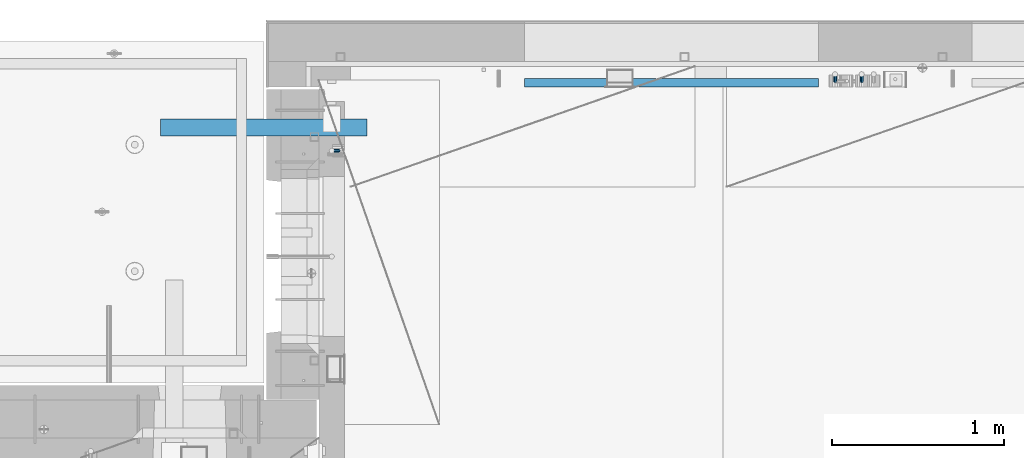
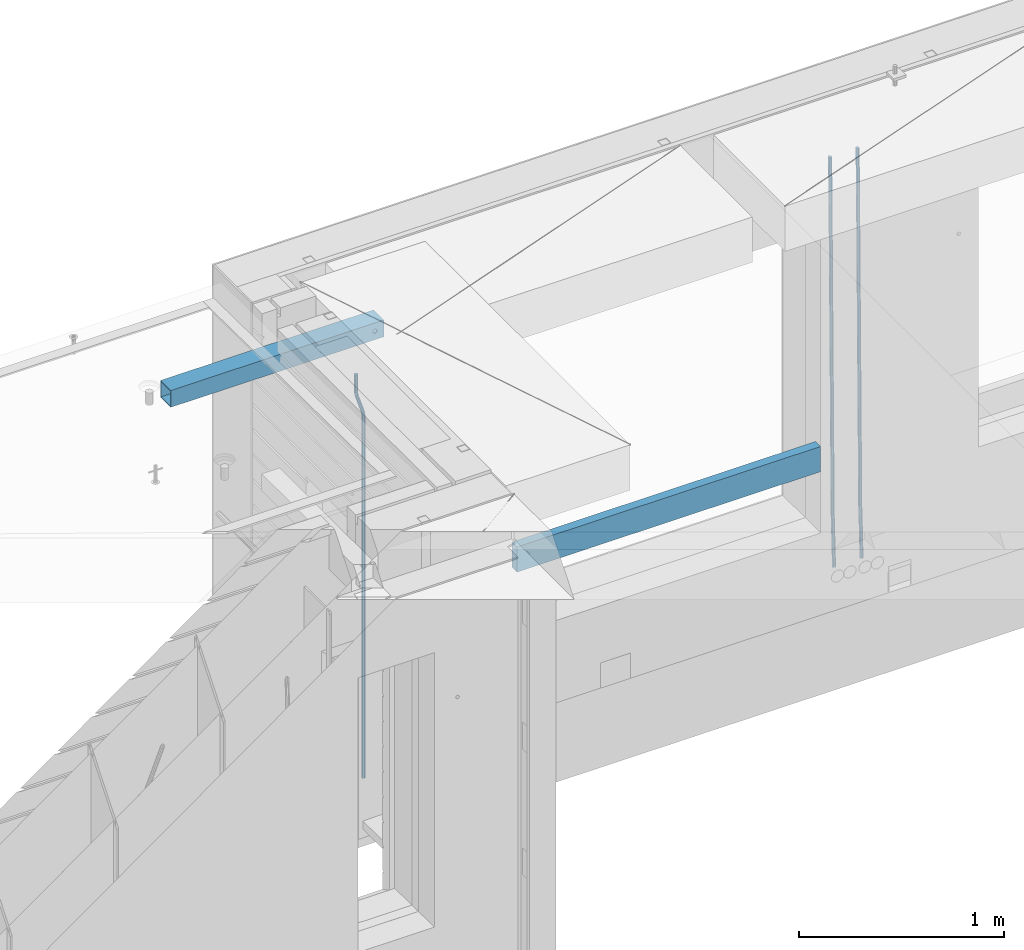
# One storey, part 117 of 350: 5 beams, 4 elements without a shape of their own.
"""IFC2X3 building model written with IfcOpenShell, lengths in millimetres."""

from ifc_helpers import new_model, si_unit, frame, origin_with_axes, place, context, subcontext, project, spatial, faceted_brep, material, type_object, element, aggregate, save


model = new_model("IFC2X3")

# Units and contexts
model_context = context("Model", 3, precision=1e-05, world=origin_with_axes())
body_context = subcontext(model_context, "Body", "Model", "MODEL_VIEW")
ifc_project = project(units=[si_unit("LENGTHUNIT", "METRE", prefix="MILLI"), si_unit("AREAUNIT", "SQUARE_METRE"), si_unit("VOLUMEUNIT", "CUBIC_METRE"), si_unit("MASSUNIT", "GRAM", prefix="KILO"), si_unit("TIMEUNIT", "SECOND"), si_unit("PLANEANGLEUNIT", "RADIAN"), si_unit("SOLIDANGLEUNIT", "STERADIAN"), si_unit("THERMODYNAMICTEMPERATUREUNIT", "DEGREE_CELSIUS"), si_unit("LUMINOUSINTENSITYUNIT", "LUMEN")], contexts=[model_context])

# Site, building, storey
site_placement = place(None, origin_with_axes())
site = spatial("IfcSite", under=ifc_project, at=site_placement, CompositionType="ELEMENT")
building_placement = place(site_placement, origin_with_axes())
building = spatial("IfcBuilding", under=site, at=building_placement, CompositionType="ELEMENT")
storey_placement = place(building_placement, origin_with_axes())
storey = spatial("IfcBuildingStorey", under=building, at=storey_placement, Name="2", CompositionType="ELEMENT", Elevation=0.0)

# Assembly, beams
assembly_1_placement = place(storey_placement, origin_with_axes())
assembly_1 = element("IfcElementAssembly", 1, at=assembly_1_placement, inside=storey, AssemblyPlace="NOTDEFINED", PredefinedType="REINFORCEMENT_UNIT")
ifc_material_1 = material()
beam_type_1 = type_object("IfcBeamType", Name="D20", PredefinedType="NOTDEFINED")
beam_1_placement = place(assembly_1_placement, frame((13990.0000000039, 22654.9999977209, 84990.0), z_axis=(-0.000205762999925498, 0.999642804629538, -0.0267249099901004), x_axis=(4.30000201928125e-08, 0.0267249099948059, 0.999642825806181)))
beam_1 = element("IfcBeam", 2, at=beam_1_placement, type_object=beam_type_1, material=ifc_material_1, Name="JM20", ObjectType="D20", context=body_context, shape_type="Brep", body=[
    faceted_brep([(0.0, -10.0, 0.0), (-4.19531716033816e-08, -7.07106781186667, -7.07106781187031), (60.4266690400545, -7.0710677960451, -7.07106780570757), (60.4266690441291, -9.99999998418934, 6.15546014159918e-09), (0.0, 0.0, -10.0), (60.426669036824, 1.58106558956206e-08, -9.99999999384454), (4.196772351861e-08, 7.07106781186303, -7.07106781186667), (60.4266690363438, 7.07106782768096, -7.07106780570757), (0.0, 10.0, 0.0), (60.4266690388904, 10.0000000158179, 6.15182216279209e-09), (4.196772351861e-08, 7.07106781185939, 7.07106781185939), (60.4266690429649, 7.07106782768096, 7.07106781802577), (0.0, 0.0, 10.0), (60.4266690461809, 1.58179318532348e-08, 10.0000000061555), (-4.19531716033816e-08, -7.07106781187031, 7.07106781185939), (60.4266690466611, -7.07106779605238, 7.07106781802213), (61.0378400410118, -7.07106779588503, -7.07106780564936), (60.991799419251, -9.99999998403655, 6.21366780251265e-09), (61.0569027789461, 1.5985278878361e-08, -9.99999999378269), (61.0378209396877, 7.07106782784831, -7.07106780564936), (60.9917724058905, 10.0000000159635, 6.21366780251265e-09), (60.9457317841297, 7.07106782781193, 7.0710678180767), (60.9266690461809, 1.59488990902901e-08, 10.0000000062028), (60.9457508854539, -7.07106779591413, 7.0710678180767), (61.6489592143771, -7.07106614513759, -7.06310863441468), (61.5568818710308, -9.9999984576425, 0.00735959856683621), (61.6870830769039, 1.71821739058942e-06, -9.99179257185824), (61.6489210170112, 7.07106947854481, -7.06310888312146), (61.556827851804, 10.0000015422847, 0.00735924683976918), (61.4647505084577, 7.07106922979438, 7.07782747982128), (61.4266266459163, 1.36643211590126e-06, 10.0065114172685), (61.464788705809, -7.07106639389531, 7.07782772852806), (176.543135720174, -7.07075579406956, -5.56673531796696), (176.451058376813, -9.99968810657447, 1.50373291501455), (176.581259582701, 0.000312069292704109, -8.49541925541052), (176.543097522794, 7.07137982961285, -5.56673556667374), (176.451004357587, 10.00031189336, 1.50373256329476), (176.35892701424, 7.07137958085514, 8.57420079627263), (176.320803151699, 0.000311717507429421, 11.5028847337162), (176.358965211621, -7.07075604281999, 8.57420104497578), (177.098753836006, -7.07075429323595, -5.55949898843028), (176.98362511232, -9.99968666800123, 1.510669025065), (177.146421932586, 0.000313595905026887, -8.48805862247536), (177.098706077581, 7.07138133041735, -5.55949936166144), (176.983557571715, 10.0003133318824, 1.51066849724157), (176.868428848029, 7.07138095712435, 8.58083651073321), (176.820760751449, 0.000313067976094317, 11.5093961447819), (176.868476606425, -7.07075466652896, 8.58083688396073), (177.654312950661, -7.07075204110879, -5.54863964998367), (177.516135294456, -9.99968450931192, 1.52107783331303), (177.711524267797, 0.000315886711177882, -8.47701274570863), (177.654255632195, 7.07138358250813, -5.54864021007961), (177.516054233929, 10.0003154905207, 1.5210770412159), (177.377876577739, 7.0713830223176, 8.59079452451624), (177.320665260588, 0.000315094497636892, 11.5191676202448), (177.377933896176, -7.07075260129932, 8.59079508461218), (299.436796249574, -7.07025836271714, -3.1681962331204), (299.298618593355, -9.99919083092027, 3.90152125031091), (299.494007566798, 0.000809565110102994, -6.09656932889993), (299.436738931283, 7.07187726089978, -3.16819679320906), (299.298537533061, 10.0008091689197, 3.90152045822106), (299.160359876842, 7.07187670072017, 10.9712379416487), (299.103148559603, 0.000808772889286047, 13.8996110374392), (299.160417195119, -7.07025892290039, 10.9712385017483), (299.98743051647, -7.07025613056248, -3.15743315966392), (299.971788958996, -9.99918809853989, 3.91467979818117), (299.993912075952, 0.000811591617093654, -6.08679785393178), (299.987423933868, 7.07187949325817, -3.1574327280432), (299.971753863239, 10.0008119014747, 3.91467990454839), (299.95611230444, 7.07187992653053, 10.9867922621015), (299.949630744944, 0.000812204350950196, 13.9161569563694), (299.956118887014, -7.07025569729012, 10.9867918304735), (300.538107039494, -7.07025785017686, -3.16575821840888), (300.644985195438, -9.99919020432935, 3.90450175465594), (300.493854948218, 0.000810030429420294, -6.09435592770024), (300.538151196495, 7.071877773491, -3.16575855385963), (300.645047642858, 10.0008097955724, 3.90450128024895), (300.751925798773, 7.07187744142357, 10.9747612533101), (300.796177890064, 0.000809560813650023, 13.9033589625978), (300.751881641787, -7.07025818224065, 10.9747615887682), (2293.36490490142, -7.07648090940347, -33.2930642912361), (2293.47178305736, -10.0054132635523, -26.2228043181785), (2293.32065281013, -0.00541302880083094, -36.2216620005347), (2293.36494905842, 7.06565471425711, -33.2930646266868), (2293.47184550477, 9.99458673634581, -26.2228047925819), (2293.57872366071, 7.06565438219332, -19.1525448195243), (2293.62297575199, -0.00541349841296324, -16.2239471102366), (2293.57867950371, -7.0764812414709, -19.1525444840736), (2294.0658245362, -7.07648309818615, -33.3036607065333), (2294.05312277409, -10.0054150789219, -26.2315929392535), (2294.10928714235, -0.00541549149056664, -36.2335844756526), (2294.15805078732, 7.06565223761572, -33.3050546393533), (2294.18355038921, 9.99458451388637, -26.2335642579346), (2294.17084862708, 7.06565253314329, -19.1614964906439), (2294.12738602093, -0.00541507354500936, -16.2315727215355), (2294.07862237596, -7.07648280265857, -19.1601025578348), (2294.76670261032, -7.08562269121467, -33.294332712383), (2294.63442802057, -10.0129954178956, -26.2238563411993), (2294.89787471293, -0.0156988342423574, -36.2230891548279), (2294.95110548967, 7.05531064255774, -33.2944998654275), (2294.89521307347, 9.98530428734011, -26.2240927312887), (2294.76293848372, 7.0579315606592, -19.1536163601049), (2294.63176638114, -0.0119922963167483, -16.2248599176673), (2294.57853560438, -7.08300177311321, -19.1534492070678), (2316.52657204497, -7.36937582653991, -33.0047303660212), (2316.39429745522, -10.2967485532172, -25.9342539948302), (2316.65774414754, -0.299451969567599, -35.9334868084661), (2316.7109749243, 6.7715575072325, -33.0048975190657), (2316.65508250811, 9.70155115201487, -25.9344903849269), (2316.52280791836, 6.7741784253376, -18.8640140137468), (2316.39163581574, -0.295745431634714, -15.9352575713092), (2316.33840503903, -7.36675490843481, -18.863846860706), (2317.16202064224, -7.37766220584308, -32.9962731735213), (2317.05438744847, -10.3053562613532, -25.9254688497131), (2317.23607125619, -0.306993473008333, -35.925789846493), (2317.23316144495, 6.76474808850253, -32.9979477328052), (2317.15499573652, 9.6950321815566, -25.9278370341635), (2317.04736254275, 6.7673381260538, -18.8570327103698), (2316.97331192881, -0.303330606784584, -15.9275160373909), (2316.97622174003, -7.37507216829545, -18.8553581510787), (2317.79752306276, -7.37578610372293, -32.9880110666527), (2317.71453320107, -10.3033876998124, -25.9168792378296), (2317.81444760226, -0.305295583297266, -35.918287695793), (2317.75539265381, 6.76628640723357, -32.9911928173897), (2317.65495180529, 9.69652304524061, -25.9213789128698), (2317.5719619436, 6.76892144914746, -18.8502470840467), (2317.55503740412, -0.301569071270933, -15.9199704549137), (2317.61409235255, -7.3731510618054, -18.847065333317), (2417.8183084176, -7.07752398473531, -31.6906369377139), (2417.73531855589, -10.0051255808248, -24.6195051088798), (2417.83523295709, -0.007033464313281, -34.6209135668432), (2417.77617800863, 7.06454852621755, -31.6938186884508), (2417.67573716014, 9.99478516423187, -24.6240047839383), (2417.59274729842, 7.06718356813872, -17.5528729551006), (2417.57582275895, -0.00330695228694822, -14.6225963259749), (2417.6348777074, -7.07488894281778, -17.5496912043673)], [[[0, 1, 2, 3]], [[1, 4, 5, 2]], [[4, 6, 7, 5]], [[6, 8, 9, 7]], [[8, 10, 11, 9]], [[10, 12, 13, 11]], [[12, 14, 15, 13]], [[14, 0, 3, 15]], [[14, 12, 10, 8, 6, 4, 1, 0]], [[3, 2, 16, 17]], [[2, 5, 18, 16]], [[5, 7, 19, 18]], [[7, 9, 20, 19]], [[9, 11, 21, 20]], [[11, 13, 22, 21]], [[13, 15, 23, 22]], [[15, 3, 17, 23]], [[17, 16, 24, 25]], [[16, 18, 26, 24]], [[18, 19, 27, 26]], [[19, 20, 28, 27]], [[20, 21, 29, 28]], [[21, 22, 30, 29]], [[22, 23, 31, 30]], [[23, 17, 25, 31]], [[25, 24, 32, 33]], [[24, 26, 34, 32]], [[26, 27, 35, 34]], [[27, 28, 36, 35]], [[28, 29, 37, 36]], [[29, 30, 38, 37]], [[30, 31, 39, 38]], [[31, 25, 33, 39]], [[33, 32, 40, 41]], [[32, 34, 42, 40]], [[34, 35, 43, 42]], [[35, 36, 44, 43]], [[36, 37, 45, 44]], [[37, 38, 46, 45]], [[38, 39, 47, 46]], [[39, 33, 41, 47]], [[41, 40, 48, 49]], [[40, 42, 50, 48]], [[42, 43, 51, 50]], [[43, 44, 52, 51]], [[44, 45, 53, 52]], [[45, 46, 54, 53]], [[46, 47, 55, 54]], [[47, 41, 49, 55]], [[49, 48, 56, 57]], [[48, 50, 58, 56]], [[50, 51, 59, 58]], [[51, 52, 60, 59]], [[52, 53, 61, 60]], [[53, 54, 62, 61]], [[54, 55, 63, 62]], [[55, 49, 57, 63]], [[57, 56, 64, 65]], [[56, 58, 66, 64]], [[58, 59, 67, 66]], [[59, 60, 68, 67]], [[60, 61, 69, 68]], [[61, 62, 70, 69]], [[62, 63, 71, 70]], [[63, 57, 65, 71]], [[65, 64, 72, 73]], [[64, 66, 74, 72]], [[66, 67, 75, 74]], [[67, 68, 76, 75]], [[68, 69, 77, 76]], [[69, 70, 78, 77]], [[70, 71, 79, 78]], [[71, 65, 73, 79]], [[73, 72, 80, 81]], [[72, 74, 82, 80]], [[74, 75, 83, 82]], [[75, 76, 84, 83]], [[76, 77, 85, 84]], [[77, 78, 86, 85]], [[78, 79, 87, 86]], [[79, 73, 81, 87]], [[81, 80, 88, 89]], [[80, 82, 90, 88]], [[82, 83, 91, 90]], [[83, 84, 92, 91]], [[84, 85, 93, 92]], [[85, 86, 94, 93]], [[86, 87, 95, 94]], [[87, 81, 89, 95]], [[89, 88, 96, 97]], [[88, 90, 98, 96]], [[90, 91, 99, 98]], [[91, 92, 100, 99]], [[92, 93, 101, 100]], [[93, 94, 102, 101]], [[94, 95, 103, 102]], [[95, 89, 97, 103]], [[97, 96, 104, 105]], [[96, 98, 106, 104]], [[98, 99, 107, 106]], [[99, 100, 108, 107]], [[100, 101, 109, 108]], [[101, 102, 110, 109]], [[102, 103, 111, 110]], [[103, 97, 105, 111]], [[105, 104, 112, 113]], [[104, 106, 114, 112]], [[106, 107, 115, 114]], [[107, 108, 116, 115]], [[108, 109, 117, 116]], [[109, 110, 118, 117]], [[110, 111, 119, 118]], [[111, 105, 113, 119]], [[113, 112, 120, 121]], [[112, 114, 122, 120]], [[114, 115, 123, 122]], [[115, 116, 124, 123]], [[116, 117, 125, 124]], [[117, 118, 126, 125]], [[118, 119, 127, 126]], [[119, 113, 121, 127]], [[121, 120, 128, 129]], [[120, 122, 130, 128]], [[122, 123, 131, 130]], [[123, 124, 132, 131]], [[124, 125, 133, 132]], [[125, 126, 134, 133]], [[126, 127, 135, 134]], [[127, 121, 129, 135]], [[130, 131, 132, 133, 134, 135, 129, 128]]]),
])
beam_2_placement = place(assembly_1_placement, frame((14145.0000000039, 22654.9999977209, 84990.0), z_axis=(-0.000205762999925498, 0.999642804629538, -0.0267249099901004), x_axis=(4.30000201928125e-08, 0.0267249099948059, 0.999642825806181)))
beam_2 = element("IfcBeam", 3, at=beam_2_placement, type_object=beam_type_1, material=ifc_material_1, Name="JM20", ObjectType="D20", context=body_context, shape_type="Brep", body=[
    faceted_brep([(0.0, -10.0, 0.0), (-4.19531716033816e-08, -7.07106781186667, -7.07106781187031), (60.4266690400545, -7.0710677960451, -7.07106780570757), (60.4266690441291, -9.99999998418934, 6.15546014159918e-09), (0.0, 0.0, -10.0), (60.426669036824, 1.58106558956206e-08, -9.99999999384454), (4.196772351861e-08, 7.07106781186303, -7.07106781186667), (60.4266690363438, 7.07106782768096, -7.07106780570757), (0.0, 10.0, 0.0), (60.4266690388904, 10.0000000158179, 6.15182216279209e-09), (4.196772351861e-08, 7.07106781185939, 7.07106781185939), (60.4266690429649, 7.07106782768096, 7.07106781802577), (0.0, 0.0, 10.0), (60.4266690461809, 1.58179318532348e-08, 10.0000000061555), (-4.19531716033816e-08, -7.07106781187031, 7.07106781185939), (60.4266690466611, -7.07106779605238, 7.07106781802213), (61.0378400410118, -7.07106779588503, -7.07106780564936), (60.991799419251, -9.99999998403655, 6.21366780251265e-09), (61.0569027789461, 1.5985278878361e-08, -9.99999999378269), (61.0378209396877, 7.07106782784831, -7.07106780564936), (60.9917724058905, 10.0000000159635, 6.21366780251265e-09), (60.9457317841297, 7.07106782781193, 7.0710678180767), (60.9266690461809, 1.59488990902901e-08, 10.0000000062028), (60.9457508854539, -7.07106779591413, 7.0710678180767), (61.6489592143771, -7.07106614513759, -7.06310863441468), (61.5568818710308, -9.9999984576425, 0.00735959856683621), (61.6870830769039, 1.71821739058942e-06, -9.99179257185824), (61.6489210170112, 7.07106947854481, -7.06310888312146), (61.556827851804, 10.0000015422847, 0.00735924683976918), (61.4647505084577, 7.07106922979438, 7.07782747982128), (61.4266266459163, 1.36643211590126e-06, 10.0065114172685), (61.464788705809, -7.07106639389531, 7.07782772852806), (176.543135720174, -7.07075579406956, -5.56673531796696), (176.451058376813, -9.99968810657447, 1.50373291501455), (176.581259582701, 0.000312069292704109, -8.49541925541052), (176.543097522794, 7.07137982961285, -5.56673556667374), (176.451004357587, 10.00031189336, 1.50373256329476), (176.35892701424, 7.07137958085514, 8.57420079627263), (176.320803151699, 0.000311717507429421, 11.5028847337162), (176.358965211621, -7.07075604281999, 8.57420104497578), (177.098753836006, -7.07075429323595, -5.55949898843028), (176.98362511232, -9.99968666800123, 1.510669025065), (177.146421932586, 0.000313595905026887, -8.48805862247536), (177.098706077581, 7.07138133041735, -5.55949936166144), (176.983557571715, 10.0003133318824, 1.51066849724157), (176.868428848029, 7.07138095712435, 8.58083651073321), (176.820760751449, 0.000313067976094317, 11.5093961447819), (176.868476606425, -7.07075466652896, 8.58083688396073), (177.654312950661, -7.07075204110879, -5.54863964998367), (177.516135294456, -9.99968450931192, 1.52107783331303), (177.711524267797, 0.000315886711177882, -8.47701274570863), (177.654255632195, 7.07138358250813, -5.54864021007961), (177.516054233929, 10.0003154905207, 1.5210770412159), (177.377876577739, 7.0713830223176, 8.59079452451624), (177.320665260588, 0.000315094497636892, 11.5191676202448), (177.377933896176, -7.07075260129932, 8.59079508461218), (299.436796249574, -7.07025836271714, -3.1681962331204), (299.298618593355, -9.99919083092027, 3.90152125031091), (299.494007566798, 0.000809565110102994, -6.09656932889993), (299.436738931283, 7.07187726089978, -3.16819679320906), (299.298537533061, 10.0008091689197, 3.90152045822106), (299.160359876842, 7.07187670072017, 10.9712379416487), (299.103148559603, 0.000808772889286047, 13.8996110374392), (299.160417195119, -7.07025892290039, 10.9712385017483), (299.98743051647, -7.07025613056248, -3.15743315966392), (299.971788958996, -9.99918809853989, 3.91467979818117), (299.993912075952, 0.000811591617093654, -6.08679785393178), (299.987423933868, 7.07187949325817, -3.1574327280432), (299.971753863239, 10.0008119014747, 3.91467990454839), (299.95611230444, 7.07187992653053, 10.9867922621015), (299.949630744944, 0.000812204350950196, 13.9161569563694), (299.956118887014, -7.07025569729012, 10.9867918304735), (300.538107039494, -7.07025785017686, -3.16575821840888), (300.644985195438, -9.99919020432935, 3.90450175465594), (300.493854948218, 0.000810030429420294, -6.09435592770024), (300.538151196495, 7.071877773491, -3.16575855385963), (300.645047642858, 10.0008097955724, 3.90450128024895), (300.751925798773, 7.07187744142357, 10.9747612533101), (300.796177890064, 0.000809560813650023, 13.9033589625978), (300.751881641787, -7.07025818224065, 10.9747615887682), (2293.36490490142, -7.07648090940347, -33.2930642912361), (2293.47178305736, -10.0054132635523, -26.2228043181785), (2293.32065281013, -0.00541302880083094, -36.2216620005347), (2293.36494905842, 7.06565471425711, -33.2930646266868), (2293.47184550477, 9.99458673634581, -26.2228047925819), (2293.57872366071, 7.06565438219332, -19.1525448195243), (2293.62297575199, -0.00541349841296324, -16.2239471102366), (2293.57867950371, -7.0764812414709, -19.1525444840736), (2294.0658245362, -7.07648309818615, -33.3036607065333), (2294.05312277409, -10.0054150789219, -26.2315929392535), (2294.10928714235, -0.00541549149056664, -36.2335844756526), (2294.15805078732, 7.06565223761572, -33.3050546393533), (2294.18355038921, 9.99458451388637, -26.2335642579346), (2294.17084862708, 7.06565253314329, -19.1614964906439), (2294.12738602093, -0.00541507354500936, -16.2315727215355), (2294.07862237596, -7.07648280265857, -19.1601025578348), (2294.76670261032, -7.08562269121467, -33.294332712383), (2294.63442802057, -10.0129954178956, -26.2238563411993), (2294.89787471293, -0.0156988342423574, -36.2230891548279), (2294.95110548967, 7.05531064255774, -33.2944998654275), (2294.89521307347, 9.98530428734011, -26.2240927312887), (2294.76293848372, 7.0579315606592, -19.1536163601049), (2294.63176638114, -0.0119922963167483, -16.2248599176673), (2294.57853560438, -7.08300177311321, -19.1534492070678), (2316.52657204497, -7.36937582653991, -33.0047303660212), (2316.39429745522, -10.2967485532172, -25.9342539948302), (2316.65774414754, -0.299451969567599, -35.9334868084661), (2316.7109749243, 6.7715575072325, -33.0048975190657), (2316.65508250811, 9.70155115201487, -25.9344903849269), (2316.52280791836, 6.7741784253376, -18.8640140137468), (2316.39163581574, -0.295745431634714, -15.9352575713092), (2316.33840503903, -7.36675490843481, -18.863846860706), (2317.16202064224, -7.37766220584308, -32.9962731735213), (2317.05438744847, -10.3053562613532, -25.9254688497131), (2317.23607125619, -0.306993473008333, -35.925789846493), (2317.23316144495, 6.76474808850253, -32.9979477328052), (2317.15499573652, 9.6950321815566, -25.9278370341635), (2317.04736254275, 6.7673381260538, -18.8570327103698), (2316.97331192881, -0.303330606784584, -15.9275160373909), (2316.97622174003, -7.37507216829545, -18.8553581510787), (2317.79752306276, -7.37578610372293, -32.9880110666527), (2317.71453320107, -10.3033876998124, -25.9168792378296), (2317.81444760226, -0.305295583297266, -35.918287695793), (2317.75539265381, 6.76628640723357, -32.9911928173897), (2317.65495180529, 9.69652304524061, -25.9213789128698), (2317.5719619436, 6.76892144914746, -18.8502470840467), (2317.55503740412, -0.301569071270933, -15.9199704549137), (2317.61409235255, -7.3731510618054, -18.847065333317), (2417.8183084176, -7.07752398473531, -31.6906369377139), (2417.73531855589, -10.0051255808248, -24.6195051088798), (2417.83523295709, -0.007033464313281, -34.6209135668432), (2417.77617800863, 7.06454852621755, -31.6938186884508), (2417.67573716014, 9.99478516423187, -24.6240047839383), (2417.59274729842, 7.06718356813872, -17.5528729551006), (2417.57582275895, -0.00330695228694822, -14.6225963259749), (2417.6348777074, -7.07488894281778, -17.5496912043673)], [[[0, 1, 2, 3]], [[1, 4, 5, 2]], [[4, 6, 7, 5]], [[6, 8, 9, 7]], [[8, 10, 11, 9]], [[10, 12, 13, 11]], [[12, 14, 15, 13]], [[14, 0, 3, 15]], [[14, 12, 10, 8, 6, 4, 1, 0]], [[3, 2, 16, 17]], [[2, 5, 18, 16]], [[5, 7, 19, 18]], [[7, 9, 20, 19]], [[9, 11, 21, 20]], [[11, 13, 22, 21]], [[13, 15, 23, 22]], [[15, 3, 17, 23]], [[17, 16, 24, 25]], [[16, 18, 26, 24]], [[18, 19, 27, 26]], [[19, 20, 28, 27]], [[20, 21, 29, 28]], [[21, 22, 30, 29]], [[22, 23, 31, 30]], [[23, 17, 25, 31]], [[25, 24, 32, 33]], [[24, 26, 34, 32]], [[26, 27, 35, 34]], [[27, 28, 36, 35]], [[28, 29, 37, 36]], [[29, 30, 38, 37]], [[30, 31, 39, 38]], [[31, 25, 33, 39]], [[33, 32, 40, 41]], [[32, 34, 42, 40]], [[34, 35, 43, 42]], [[35, 36, 44, 43]], [[36, 37, 45, 44]], [[37, 38, 46, 45]], [[38, 39, 47, 46]], [[39, 33, 41, 47]], [[41, 40, 48, 49]], [[40, 42, 50, 48]], [[42, 43, 51, 50]], [[43, 44, 52, 51]], [[44, 45, 53, 52]], [[45, 46, 54, 53]], [[46, 47, 55, 54]], [[47, 41, 49, 55]], [[49, 48, 56, 57]], [[48, 50, 58, 56]], [[50, 51, 59, 58]], [[51, 52, 60, 59]], [[52, 53, 61, 60]], [[53, 54, 62, 61]], [[54, 55, 63, 62]], [[55, 49, 57, 63]], [[57, 56, 64, 65]], [[56, 58, 66, 64]], [[58, 59, 67, 66]], [[59, 60, 68, 67]], [[60, 61, 69, 68]], [[61, 62, 70, 69]], [[62, 63, 71, 70]], [[63, 57, 65, 71]], [[65, 64, 72, 73]], [[64, 66, 74, 72]], [[66, 67, 75, 74]], [[67, 68, 76, 75]], [[68, 69, 77, 76]], [[69, 70, 78, 77]], [[70, 71, 79, 78]], [[71, 65, 73, 79]], [[73, 72, 80, 81]], [[72, 74, 82, 80]], [[74, 75, 83, 82]], [[75, 76, 84, 83]], [[76, 77, 85, 84]], [[77, 78, 86, 85]], [[78, 79, 87, 86]], [[79, 73, 81, 87]], [[81, 80, 88, 89]], [[80, 82, 90, 88]], [[82, 83, 91, 90]], [[83, 84, 92, 91]], [[84, 85, 93, 92]], [[85, 86, 94, 93]], [[86, 87, 95, 94]], [[87, 81, 89, 95]], [[89, 88, 96, 97]], [[88, 90, 98, 96]], [[90, 91, 99, 98]], [[91, 92, 100, 99]], [[92, 93, 101, 100]], [[93, 94, 102, 101]], [[94, 95, 103, 102]], [[95, 89, 97, 103]], [[97, 96, 104, 105]], [[96, 98, 106, 104]], [[98, 99, 107, 106]], [[99, 100, 108, 107]], [[100, 101, 109, 108]], [[101, 102, 110, 109]], [[102, 103, 111, 110]], [[103, 97, 105, 111]], [[105, 104, 112, 113]], [[104, 106, 114, 112]], [[106, 107, 115, 114]], [[107, 108, 116, 115]], [[108, 109, 117, 116]], [[109, 110, 118, 117]], [[110, 111, 119, 118]], [[111, 105, 113, 119]], [[113, 112, 120, 121]], [[112, 114, 122, 120]], [[114, 115, 123, 122]], [[115, 116, 124, 123]], [[116, 117, 125, 124]], [[117, 118, 126, 125]], [[118, 119, 127, 126]], [[119, 113, 121, 127]], [[121, 120, 128, 129]], [[120, 122, 130, 128]], [[122, 123, 131, 130]], [[123, 124, 132, 131]], [[124, 125, 133, 132]], [[125, 126, 134, 133]], [[126, 127, 135, 134]], [[127, 121, 129, 135]], [[130, 131, 132, 133, 134, 135, 129, 128]]]),
])

# Assembly, beam
assembly_2_placement = place(storey_placement, origin_with_axes())
assembly_2 = element("IfcElementAssembly", 4, at=assembly_2_placement, inside=storey, AssemblyPlace="NOTDEFINED", PredefinedType="REINFORCEMENT_UNIT")
beam_3_placement = place(assembly_2_placement, frame((11065.0, 22249.9963332647, 87407.5), z_axis=(0.999999913638316, -0.000415599999849952, 0.0), x_axis=(0.0, 0.0, -1.0)))
beam_3 = element("IfcBeam", 5, at=beam_3_placement, type_object=beam_type_1, material=ifc_material_1, Name="JM20", ObjectType="D20", context=body_context, shape_type="Brep", body=[
    faceted_brep([(0.0, -10.0, 0.0), (-4.19531716033816e-08, -7.07106781186667, -7.07106781187031), (113.248091332178, -7.0710684840451, -7.0710678117357), (113.248091314759, -10.0000006713562, -2.51020537689328e-10), (0.0, 0.0, -10.0), (113.248091374131, -6.72178430249915e-07, -9.99999999986903), (4.196772351861e-08, 7.07106781186303, -7.07106781186667), (113.248091416113, 7.07106713968824, -7.07106781173934), (0.0, 10.0, 0.0), (113.248091433488, 9.99999932782521, 1.30967237055302e-10), (4.196772351861e-08, 7.07106781185939, 7.07106781185939), (113.248091416113, 7.0710671396846, 7.071067811994), (0.0, 0.0, 10.0), (113.248091374131, -6.72174792271107e-07, 10.0000000001273), (-4.19531716033816e-08, -7.07106781187031, 7.07106781185939), (113.248091332178, -7.0710684840451, 7.071067811994), (130.699843527167, -7.06993249763036, -4.33745683788584), (128.538066582521, -9.99900540317321, 2.39499413731755), (131.594536475241, 0.00119355250353692, -7.12624594330919), (130.698046432328, 7.07220300913468, -4.33773834422391), (128.535525107087, 10.0009944322555, 2.39459602660281), (126.373748162892, 7.07192152754578, 9.1270470011732), (125.479055214906, 0.000795477419160306, 11.9158361066184), (126.37554525779, -7.07021397921199, 9.12732850753673), (240.336258550378, -7.05529970173666, 30.8729495437874), (238.174481606227, -9.98437260450009, 37.6054005176375), (241.230951498423, 0.0158263482953771, 28.0841604381058), (240.334461455612, 7.0868358050102, 30.8726680369582), (238.171940130502, 10.0156272283348, 37.6050024077231), (236.010163186409, 7.08655432384694, 44.3374533824244), (235.115470238379, 0.0154282738185429, 47.1262424881097), (236.011960281176, -7.05558118289991, 44.3377348892536), (253.461915329972, -7.05444528127919, 32.9289287376414), (253.46191532613, -9.98337746617108, 39.9999965521893), (253.461915339081, 0.0166225284556276, 29.9999965443676), (253.461915348205, 7.08769034247234, 32.9289287273205), (253.461915352003, 10.0166225357716, 39.9999965370152), (253.461915348293, 7.08769035281148, 47.0710643509774), (253.461915339183, 0.0166225430875784, 49.999996544273), (253.46191533003, -7.05444527093641, 47.0710643613093), (2417.50000002384, -7.0544364694706, 32.9289287374122), (2417.5000000337, -9.98336865393321, 39.9999965507959), (2417.49999999997, 0.0166313408753922, 29.9999965456082), (2417.49999997609, 7.08769915426274, 32.9289287300708), (2417.4999999662, 10.0166313460668, 39.9999965404204), (2417.49999997608, 7.08769916160054, 47.0710643538114), (2417.49999999994, 0.0166313512581837, 49.9999965456154), (2417.50000002382, -7.05443646212916, 47.0710643611455)], [[[0, 1, 2, 3]], [[1, 4, 5, 2]], [[4, 6, 7, 5]], [[6, 8, 9, 7]], [[8, 10, 11, 9]], [[10, 12, 13, 11]], [[12, 14, 15, 13]], [[14, 0, 3, 15]], [[14, 12, 10, 8, 6, 4, 1, 0]], [[3, 2, 16, 17]], [[2, 5, 18, 16]], [[5, 7, 19, 18]], [[7, 9, 20, 19]], [[9, 11, 21, 20]], [[11, 13, 22, 21]], [[13, 15, 23, 22]], [[15, 3, 17, 23]], [[17, 16, 24, 25]], [[16, 18, 26, 24]], [[18, 19, 27, 26]], [[19, 20, 28, 27]], [[20, 21, 29, 28]], [[21, 22, 30, 29]], [[22, 23, 31, 30]], [[23, 17, 25, 31]], [[25, 24, 32, 33]], [[24, 26, 34, 32]], [[26, 27, 35, 34]], [[27, 28, 36, 35]], [[28, 29, 37, 36]], [[29, 30, 38, 37]], [[30, 31, 39, 38]], [[31, 25, 33, 39]], [[33, 32, 40, 41]], [[32, 34, 42, 40]], [[34, 35, 43, 42]], [[35, 36, 44, 43]], [[36, 37, 45, 44]], [[37, 38, 46, 45]], [[38, 39, 47, 46]], [[39, 33, 41, 47]], [[42, 43, 44, 45, 46, 47, 41, 40]]]),
])
aggregate(assembly_2, [beam_3])

# Beam
ifc_material_2 = material(Name="TIMBER/T24")
beam_type_2 = type_object("IfcBeamType", PredefinedType="NOTDEFINED")
beam_4_placement = place(assembly_1_placement, frame((13895.0002980493, 22644.9998418812, 85685.0), z_axis=(0.0, 0.0, 1.0), x_axis=(-1.0, 3.00000001838171e-08, 0.0)))
beam_4 = element("IfcBeam", 6, at=beam_4_placement, type_object=beam_type_2, material=ifc_material_2, context=body_context, shape_type="Brep", body=[
    faceted_brep([(-3.63797880709171e-12, 24.9999999999964, -75.0), (-3.63797880709171e-12, 24.9999999999964, 75.0), (1710.0, 25.0, 75.0), (1710.0, 25.0, -75.0), (0.0, -25.0000000000073, 75.0), (1709.99999999999, -25.0, 75.0), (0.0, -25.0000000000073, -75.0), (1709.99999999999, -25.0, -75.0)], [[[0, 1, 2, 3]], [[1, 4, 5, 2]], [[4, 6, 7, 5]], [[6, 0, 3, 7]], [[5, 7, 3, 2]], [[6, 4, 1, 0]]]),
])

aggregate(assembly_1, [beam_1, beam_2, beam_4])

# Assemblies, beam
assembly_3_placement = place(storey_placement, origin_with_axes())
assembly_3 = element("IfcElementAssembly", 7, at=assembly_3_placement, inside=storey, AssemblyPlace="NOTDEFINED", PredefinedType="REINFORCEMENT_UNIT")
assembly_4_placement = place(assembly_3_placement, origin_with_axes())
assembly_4 = element("IfcElementAssembly", 8, at=assembly_4_placement, AssemblyPlace="NOTDEFINED", PredefinedType="NOTDEFINED")
aggregate(assembly_3, [assembly_4])
ifc_material_3 = material(Name="Undefined/350")
beam_type_3 = type_object("IfcBeamType", Name="100X100X5", PredefinedType="NOTDEFINED")
beam_5_placement = place(assembly_4_placement, frame((10069.9865573969, 22385.0401432011, 87555.0), z_axis=(0.0, 0.0, 1.0), x_axis=(0.999999999752625, -2.22429999942101e-05, 0.0)))
beam_5 = element("IfcBeam", 9, at=beam_5_placement, type_object=beam_type_3, material=ifc_material_3, ObjectType="100X100X5", context=body_context, shape_type="Brep", body=[
    faceted_brep([(1156.2510802317, 44.9999999999982, 10.8253175473074), (1156.25107855315, 50.0256005946221, 10.8253175473074), (1160.82639610046, 50.0256021227788, 6.25), (1160.82639777901, 44.9999999999982, 6.25), (1150.00108023171, 44.9999999999982, 12.5), (1150.00107855316, 50.0255985071226, 12.5), (1143.75108023171, 44.9999999999982, 10.8253175473074), (1143.75107855316, 50.0255964196231, 10.8253175473074), (1139.1757626844, 44.9999999999982, 6.25), (1139.17576100585, 50.0255948914664, 6.25), (1137.5010802317, 44.9999999999982, 0.0), (1137.50107855316, 50.0255943321226, 0.0), (1139.1757626844, 44.9999999999982, -6.25), (1139.17576100585, 50.0255948914664, -6.25), (1143.75108023171, 44.9999999999982, -10.8253175473074), (1143.75107855316, 50.0255964196231, -10.8253175473074), (1150.00108023171, 44.9999999999982, -12.5), (1150.00107855316, 50.0255985071226, -12.5), (1156.2510802317, 44.9999999999982, -10.8253175473074), (1156.25107855315, 50.0256005946221, -10.8253175473074), (1160.82639777901, 44.9999999999982, -6.25), (1160.82639610046, 50.0256021227788, -6.25), (1162.50108023171, 44.9999999999982, 0.0), (1162.50107855316, 50.0256026821226, 0.0), (1156.25111195316, -49.9743994042774, 10.8253175473074), (1156.25111029171, -44.9999999999991, 10.8253175473074), (1160.82642783901, -44.9999999999991, 6.25), (1160.82642950046, -49.9743978761207, 6.25), (1150.00111195316, -49.9744014917787, 12.5), (1150.00111029171, -44.9999999999991, 12.5), (1143.75111195316, -49.9744035792783, 10.8253175473074), (1143.75111029171, -44.9999999999991, 10.8253175473074), (1139.17579440585, -49.9744051074349, 6.25), (1139.1757927444, -44.9999999999991, 6.25), (1137.50111195316, -49.9744056667778, 0.0), (1137.50111029171, -44.9999999999991, 0.0), (1139.17579440585, -49.9744051074349, -6.25), (1139.1757927444, -44.9999999999991, -6.25), (1143.75111195316, -49.9744035792783, -10.8253175473074), (1143.75111029171, -44.9999999999991, -10.8253175473074), (1150.00111195316, -49.9744014917787, -12.5), (1150.00111029171, -44.9999999999991, -12.5), (1156.25111195316, -49.9743994042774, -10.8253175473074), (1156.25111029171, -44.9999999999991, -10.8253175473074), (1160.82642950046, -49.9743978761207, -6.25), (1160.82642783901, -44.9999999999991, -6.25), (1162.50111195316, -49.9743973167779, 0.0), (1162.50111029171, -44.9999999999991, 0.0), (1.81898940354586e-12, -50.0000000000009, -50.0), (1.81898940354586e-12, 49.9999999999991, -50.0), (1200.00449189278, 49.9999999999982, -50.0), (1200.00449189278, -50.0000000000009, -50.0), (1.81898940354586e-12, 49.9999999999991, 50.0), (1.81898940354586e-12, -50.0000000000009, 50.0), (1200.00449189278, -50.0000000000009, 50.0), (1200.00449189278, 49.9999999999982, 50.0), (0.0, 44.9999999999991, 45.0), (1.81898940354586e-12, -45.0000000000009, 45.0), (1.81898940354586e-12, -45.0000000000009, -45.0), (0.0, 44.9999999999991, -45.0), (1200.00449189278, 44.9999999999982, -45.0), (1200.00449189278, 44.9999999999982, 45.0), (1200.00449189278, -45.0000000000009, 45.0), (1200.00449189278, -45.0000000000009, -45.0)], [[[0, 1, 2, 3]], [[4, 5, 1, 0]], [[6, 7, 5, 4]], [[8, 9, 7, 6]], [[10, 11, 9, 8]], [[12, 13, 11, 10]], [[14, 15, 13, 12]], [[16, 17, 15, 14]], [[18, 19, 17, 16]], [[20, 21, 19, 18]], [[22, 23, 21, 20]], [[3, 2, 23, 22]], [[24, 25, 26, 27]], [[28, 29, 25, 24]], [[30, 31, 29, 28]], [[32, 33, 31, 30]], [[34, 35, 33, 32]], [[36, 37, 35, 34]], [[38, 39, 37, 36]], [[40, 41, 39, 38]], [[42, 43, 41, 40]], [[44, 45, 43, 42]], [[46, 47, 45, 44]], [[27, 26, 47, 46]], [[48, 49, 50, 51]], [[52, 53, 54, 55]], [[49, 52, 55, 50], [1, 5, 7, 9, 11, 13, 15, 17, 19, 21, 23, 2]], [[48, 53, 52, 49], [56, 57, 58, 59]], [[56, 59, 60, 61], [18, 16, 14, 12, 10, 8, 6, 4, 0, 3, 22, 20]], [[57, 56, 61, 62]], [[58, 57, 62, 63], [25, 29, 31, 33, 35, 37, 39, 41, 43, 45, 47, 26]], [[59, 58, 63, 60]], [[54, 51, 50, 55], [62, 61, 60, 63]], [[53, 48, 51, 54], [42, 40, 38, 36, 34, 32, 30, 28, 24, 27, 46, 44]]]),
])
aggregate(assembly_4, [beam_5])

save(model, "model.ifc")
